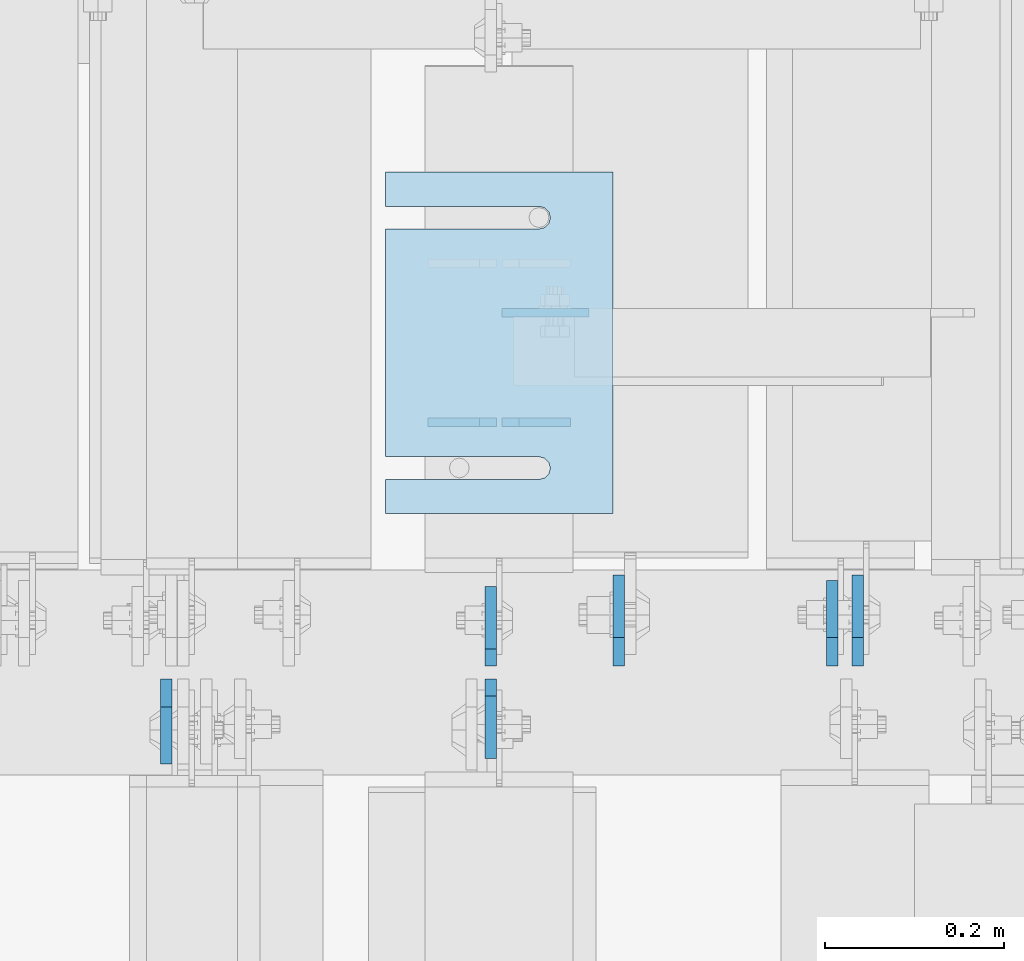
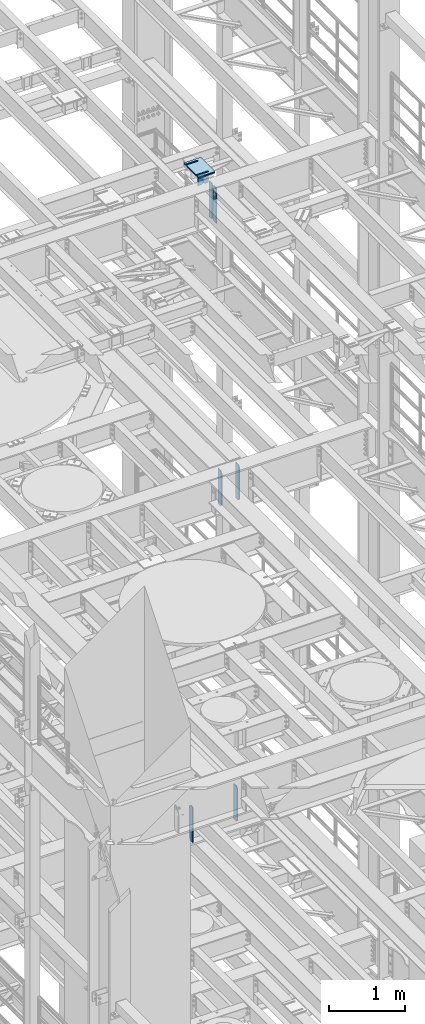
# One storey, part 1722 of 1876: 15 plates, 10 elements without a shape of their own.
"""IFC2X3 building model written with IfcOpenShell, lengths in millimetres."""

from ifc_helpers import new_model, si_unit, frame, origin_with_axes, place, context, subcontext, project, spatial, faceted_brep, material, type_object, element, aggregate, save


model = new_model("IFC2X3")

# Units and contexts
model_context = context("Model", 3, precision=1e-05, world=origin_with_axes())
body_context = subcontext(model_context, "Body", "Model", "MODEL_VIEW")
ifc_project = project(units=[si_unit("LENGTHUNIT", "METRE", prefix="MILLI"), si_unit("AREAUNIT", "SQUARE_METRE"), si_unit("VOLUMEUNIT", "CUBIC_METRE"), si_unit("MASSUNIT", "GRAM", prefix="KILO"), si_unit("TIMEUNIT", "SECOND"), si_unit("PLANEANGLEUNIT", "RADIAN"), si_unit("SOLIDANGLEUNIT", "STERADIAN"), si_unit("THERMODYNAMICTEMPERATUREUNIT", "DEGREE_CELSIUS"), si_unit("LUMINOUSINTENSITYUNIT", "LUMEN")], contexts=[model_context])

# Site, building, storey
site_placement = place(None, origin_with_axes())
site = spatial("IfcSite", under=ifc_project, at=site_placement, CompositionType="ELEMENT")
building_placement = place(site_placement, origin_with_axes())
building = spatial("IfcBuilding", under=site, at=building_placement, Name="Undefined", CompositionType="ELEMENT")
storey_placement = place(building_placement, origin_with_axes())
storey = spatial("IfcBuildingStorey", under=building, at=storey_placement, Name="Undefined", CompositionType="ELEMENT", Elevation=0.0)

# Assembly, plates
assembly_1_placement = place(storey_placement, origin_with_axes())
assembly_1 = element("IfcElementAssembly", 1, at=assembly_1_placement, inside=storey, Name="BEAM", AssemblyPlace="NOTDEFINED", PredefinedType="RIGID_FRAME")
ifc_material = material(Name="STEEL/A36")
plate_type_1 = type_object("IfcPlateType", PredefinedType="NOTDEFINED")
plate_1_placement = place(assembly_1_placement, frame((5184.77530602581, 7898.88123125041, 17792.7), z_axis=(0.0, 0.0, 1.0), x_axis=(-1.0, 0.0, 0.0)))
plate_1 = element("IfcPlate", 2, at=plate_1_placement, type_object=plate_type_1, material=ifc_material, Name="PLATE", context=body_context, shape_type="Brep", body=[
    faceted_brep([(0.0, -4.76249999999982, 0.0), (0.0, -4.76249999999982, 180.975006103516), (0.0, 4.76249999999982, 180.975006103516), (0.0, 4.76249999999982, 0.0), (57.1499977111816, -4.76249999999982, 180.975006103516), (57.1499977111816, 4.76249999999982, 180.975006103516), (76.1999969482422, -4.76249999999982, 161.925006866455), (76.1999969482422, 4.76249999999982, 161.925006866455), (76.1999969482422, -4.76249999999982, 19.0499992370605), (76.1999969482422, 4.76249999999982, 19.0499992370605), (57.1499977111816, -4.76249999999982, 0.0), (57.1499977111816, 4.76249999999982, 0.0)], [[[0, 1, 2, 3]], [[1, 4, 5, 2]], [[4, 6, 7, 5]], [[6, 8, 9, 7]], [[8, 10, 11, 9]], [[10, 0, 3, 11]], [[5, 7, 9, 11, 3, 2]], [[10, 8, 6, 4, 1, 0]]]),
])
plate_2_placement = place(assembly_1_placement, frame((5102.22530602581, 7898.88123125041, 17792.7), z_axis=(0.0, 0.0, 1.0), x_axis=(-1.0, 0.0, 0.0)))
plate_2 = element("IfcPlate", 3, at=plate_2_placement, type_object=plate_type_1, material=ifc_material, Name="PLATE", context=body_context, shape_type="Brep", body=[
    faceted_brep([(0.0, -4.76249999999982, 19.0499992370605), (0.0, -4.76249999999982, 161.925006866455), (0.0, 4.76249999999982, 161.925006866455), (0.0, 4.76249999999982, 19.0499992370605), (19.0499992370605, -4.76249999999982, 180.975006103516), (19.0499992370605, 4.76249999999982, 180.975006103516), (76.1999969482422, -4.76249999999982, 180.975006103516), (76.1999969482422, 4.76249999999982, 180.975006103516), (76.1999969482422, -4.76250000000073, 0.0), (76.1999969482422, 4.76250000000073, 0.0), (19.0499992370605, -4.76249999999982, 0.0), (19.0499992370605, 4.76249999999982, 0.0)], [[[0, 1, 2, 3]], [[1, 4, 5, 2]], [[4, 6, 7, 5]], [[6, 8, 9, 7]], [[8, 10, 11, 9]], [[10, 0, 3, 11]], [[5, 7, 9, 11, 3, 2]], [[10, 8, 6, 4, 1, 0]]]),
])
plate_type_2 = type_object("IfcPlateType", PredefinedType="NOTDEFINED")
plate_3_placement = place(assembly_1_placement, frame((5205.7390194183, 8021.0448743066, 17792.7), z_axis=(-1.0, 0.0, 0.0), x_axis=(0.0, 0.0, 1.0)))
plate_3 = element("IfcPlate", 4, at=plate_3_placement, type_object=plate_type_2, material=ifc_material, Name="PLATE", context=body_context, shape_type="Brep", body=[
    faceted_brep([(0.0, -4.76249999999982, 0.0), (-3.67032225767616e-05, -4.76249999998254, 84.4636888504128), (-3.67032225767616e-05, 4.7625000000171, 84.4636888504101), (0.0, 4.76249999999982, 0.0), (12.6999575873306, -4.76249999997981, 97.1636989145009), (12.6999575873306, 4.76250000001983, 97.163698914499), (85.0369567871567, -4.76249999998072, 97.1637573241951), (85.0369567871567, 4.76250000001983, 97.1637573241933), (85.0369949340893, -4.76250000000073, -1.68256519827992e-10), (85.0369949340893, 4.76249999999891, -1.70075509231538e-10)], [[[0, 1, 2, 3]], [[1, 4, 5, 2]], [[4, 6, 7, 5]], [[6, 8, 9, 7]], [[8, 0, 3, 9]], [[5, 7, 9, 3, 2]], [[8, 6, 4, 1, 0]]]),
])
aggregate(assembly_1, [plate_1, plate_2, plate_3])

assembly_2_placement = place(storey_placement, origin_with_axes())
assembly_2 = element("IfcElementAssembly", 5, at=assembly_2_placement, inside=storey, Name="BEAM", AssemblyPlace="NOTDEFINED", PredefinedType="RIGID_FRAME")
plate_type_3 = type_object("IfcPlateType", PredefinedType="NOTDEFINED")
plate_4_placement = place(assembly_2_placement, frame((5095.87401441426, 7612.85625, 17387.8875), z_axis=(0.0, 0.0, 1.0), x_axis=(0.0, -1.0, 0.0)))
plate_4 = element("IfcPlate", 6, at=plate_4_placement, type_object=plate_type_3, material=ifc_material, Name="PLATE", context=body_context, shape_type="Brep", body=[
    faceted_brep([(0.0, -6.35000000000196, 19.0499992370605), (0.0, -6.34999999999991, 550.862476348877), (0.0, 6.34999999999991, 550.862476348877), (0.0, 6.35000000000105, 19.0499992370605), (19.0499992370605, -6.34999999999991, 569.912475585938), (19.0499992370605, 6.34999999999991, 569.912475585938), (88.9000015258616, -6.35000000001173, 569.912475585938), (88.9000015258634, 6.34999999998627, 569.912475585938), (88.9000015258789, -6.34999999999991, 0.0), (88.9000015258789, 6.34999999999991, 0.0), (19.0499992370642, -6.35000000000105, 0.0), (19.0499992370633, 6.35000000000105, 0.0)], [[[0, 1, 2, 3]], [[1, 4, 5, 2]], [[4, 6, 7, 5]], [[6, 8, 9, 7]], [[8, 10, 11, 9]], [[10, 0, 3, 11]], [[5, 7, 9, 11, 3, 2]], [[10, 8, 6, 4, 1, 0]]]),
])
plate_5_placement = place(assembly_2_placement, frame((5095.87530593044, 7627.14375, 17387.8875), z_axis=(0.0, 0.0, 1.0), x_axis=(0.0, 1.0, 0.0)))
plate_5 = element("IfcPlate", 7, at=plate_5_placement, type_object=plate_type_3, material=ifc_material, Name="PLATE", context=body_context, shape_type="Brep", body=[
    faceted_brep([(0.0, -6.35000000000196, 19.0499992370605), (0.0, -6.34999999999991, 550.862476348877), (0.0, 6.34999999999991, 550.862476348877), (0.0, 6.35000000000105, 19.0499992370605), (19.0499992370605, -6.34999999999991, 569.912475585938), (19.0499992370605, 6.34999999999991, 569.912475585938), (88.9000015258616, -6.35000000001173, 569.912475585938), (88.9000015258634, 6.34999999998627, 569.912475585938), (88.9000015258789, -6.34999999999991, 0.0), (88.9000015258789, 6.34999999999991, 0.0), (19.0499992370642, -6.35000000000105, 0.0), (19.0499992370633, 6.35000000000105, 0.0)], [[[0, 1, 2, 3]], [[1, 4, 5, 2]], [[4, 6, 7, 5]], [[6, 8, 9, 7]], [[8, 10, 11, 9]], [[10, 0, 3, 11]], [[5, 7, 9, 11, 3, 2]], [[10, 8, 6, 4, 1, 0]]]),
])
aggregate(assembly_2, [plate_4, plate_5])

assembly_3_placement = place(storey_placement, origin_with_axes())
assembly_3 = element("IfcElementAssembly", 8, at=assembly_3_placement, inside=storey, Name="BEAM", AssemblyPlace="NOTDEFINED", PredefinedType="RIGID_FRAME")
plate_type_4 = type_object("IfcPlateType", PredefinedType="NOTDEFINED")
plate_6_placement = place(assembly_3_placement, frame((4733.92499990463, 7612.85625, 7558.0875), z_axis=(0.0, 0.0, 1.0), x_axis=(0.0, -1.0, 0.0)))
plate_6 = element("IfcPlate", 9, at=plate_6_placement, type_object=plate_type_4, material=ifc_material, Name="PLATE", context=body_context, shape_type="Brep", body=[
    faceted_brep([(0.0, -6.34999999999991, 31.75), (0.0, -6.35000000000036, 538.162475585938), (0.0, 6.35000000000036, 538.162475585938), (0.0, 6.34999999999991, 31.75), (31.75, -6.35000000000036, 569.912475585938), (31.75, 6.35000000000036, 569.912475585938), (95.25, -6.35000000000036, 569.912475585938), (95.25, 6.35000000000036, 569.912475585938), (95.25, -6.35000000000036, 0.0), (95.25, 6.35000000000036, 0.0), (31.75, -6.34999999999991, 0.0), (31.75, 6.34999999999991, 0.0)], [[[0, 1, 2, 3]], [[1, 4, 5, 2]], [[4, 6, 7, 5]], [[6, 8, 9, 7]], [[8, 10, 11, 9]], [[10, 0, 3, 11]], [[5, 7, 9, 11, 3, 2]], [[10, 8, 6, 4, 1, 0]]]),
])
plate_7_placement = place(assembly_3_placement, frame((5476.87499990463, 7627.14375, 7558.0875), z_axis=(0.0, 0.0, 1.0), x_axis=(0.0, 1.0, 0.0)))
plate_7 = element("IfcPlate", 10, at=plate_7_placement, type_object=plate_type_4, material=ifc_material, Name="PLATE", context=body_context, shape_type="Brep", body=[
    faceted_brep([(0.0, -6.34999999999991, 31.75), (0.0, -6.35000000000036, 538.162475585938), (0.0, 6.35000000000036, 538.162475585938), (0.0, 6.34999999999991, 31.75), (31.75, -6.35000000000036, 569.912475585938), (31.75, 6.35000000000036, 569.912475585938), (95.25, -6.35000000000036, 569.912475585938), (95.25, 6.35000000000036, 569.912475585938), (95.25, -6.35000000000036, 0.0), (95.25, 6.35000000000036, 0.0), (31.75, -6.34999999999991, 0.0), (31.75, 6.34999999999991, 0.0)], [[[0, 1, 2, 3]], [[1, 4, 5, 2]], [[4, 6, 7, 5]], [[6, 8, 9, 7]], [[8, 10, 11, 9]], [[10, 0, 3, 11]], [[5, 7, 9, 11, 3, 2]], [[10, 8, 6, 4, 1, 0]]]),
])
aggregate(assembly_3, [plate_6, plate_7])

assembly_4_placement = place(storey_placement, origin_with_axes())
assembly_4 = element("IfcElementAssembly", 11, at=assembly_4_placement, inside=storey, Name="BEAM", AssemblyPlace="NOTDEFINED", PredefinedType="RIGID_FRAME")
plate_type_5 = type_object("IfcPlateType", PredefinedType="NOTDEFINED")
plate_8_placement = place(assembly_4_placement, frame((5505.44999990463, 7627.14375, 12714.2875), z_axis=(0.0, 0.0, 1.0), x_axis=(0.0, 1.0, 0.0)))
plate_8 = element("IfcPlate", 12, at=plate_8_placement, type_object=plate_type_5, material=ifc_material, Name="PLATE", context=body_context, shape_type="Brep", body=[
    faceted_brep([(0.0, -6.34999999999991, 31.75), (0.0, -6.35000000000036, 538.162475585938), (0.0, 6.35000000000036, 538.162475585938), (0.0, 6.34999999999991, 31.75), (31.75, -6.35000000000036, 569.912475585938), (31.75, 6.35000000000036, 569.912475585938), (101.599998474121, -6.34999999999991, 569.912475585938), (101.599998474121, 6.34999999999991, 569.912475585938), (101.599998474121, -6.35000000000036, 0.0), (101.599998474121, 6.35000000000036, 0.0), (31.75, -6.34999999999991, 0.0), (31.75, 6.34999999999991, 0.0)], [[[0, 1, 2, 3]], [[1, 4, 5, 2]], [[4, 6, 7, 5]], [[6, 8, 9, 7]], [[8, 10, 11, 9]], [[10, 0, 3, 11]], [[5, 7, 9, 11, 3, 2]], [[10, 8, 6, 4, 1, 0]]]),
])
plate_9_placement = place(assembly_4_placement, frame((5238.74999834896, 7627.14375, 12714.2875), z_axis=(0.0, 0.0, 1.0), x_axis=(0.0, 1.0, 0.0)))
plate_9 = element("IfcPlate", 13, at=plate_9_placement, type_object=plate_type_5, material=ifc_material, Name="PLATE", context=body_context, shape_type="Brep", body=[
    faceted_brep([(0.0, -6.34999999999991, 31.75), (0.0, -6.35000000000036, 538.162475585938), (0.0, 6.35000000000036, 538.162475585938), (0.0, 6.34999999999991, 31.75), (31.75, -6.35000000000036, 569.912475585938), (31.75, 6.35000000000036, 569.912475585938), (101.599998474121, -6.34999999999991, 569.912475585938), (101.599998474121, 6.34999999999991, 569.912475585938), (101.599998474121, -6.35000000000036, 0.0), (101.599998474121, 6.35000000000036, 0.0), (31.75, -6.34999999999991, 0.0), (31.75, 6.34999999999991, 0.0)], [[[0, 1, 2, 3]], [[1, 4, 5, 2]], [[4, 6, 7, 5]], [[6, 8, 9, 7]], [[8, 10, 11, 9]], [[10, 0, 3, 11]], [[5, 7, 9, 11, 3, 2]], [[10, 8, 6, 4, 1, 0]]]),
])
aggregate(assembly_4, [plate_8, plate_9])

# Assembly, plate
assembly_5_placement = place(storey_placement, origin_with_axes())
assembly_5 = element("IfcElementAssembly", 14, at=assembly_5_placement, inside=storey, Name="SHIM PLATE", AssemblyPlace="NOTDEFINED", PredefinedType="RIGID_FRAME")
plate_type_6 = type_object("IfcPlateType", PredefinedType="NOTDEFINED")
plate_10_placement = place(assembly_5_placement, frame((5232.40173712284, 8178.20538047697, 18007.0115), z_axis=(-1.0, 0.0, 0.0), x_axis=(0.0, -1.0, 0.0)))
plate_10 = element("IfcPlate", 15, at=plate_10_placement, type_object=plate_type_6, material=ifc_material, Name="SHIM PLATE", context=body_context, shape_type="Brep", body=[
    faceted_brep([(38.1710562683074, -1.58750000000146, 253.999557495119), (38.1732778844053, -1.58750000000146, 82.6182316462764), (38.1732778844053, 1.58750000000146, 82.6182316462764), (38.1710562683074, 1.58750000000146, 253.999557495119), (39.8747477728821, -1.58750000000146, 76.2682283464169), (39.8747477728821, 1.58750000000146, 76.2682283464169), (44.523266268131, -1.58750000000146, 71.6196998169826), (44.523266268131, 1.58750000000146, 71.6196998169826), (50.8732658952267, -1.58750000000146, 69.9182162215529), (50.8732658952267, 1.58750000000146, 69.9182162215529), (57.2232684284982, -1.58750000000146, 71.6196889709886), (57.2232684284982, 1.58750000000146, 71.6196889709886), (61.8717948635667, -1.58750000000146, 76.2682095606051), (61.8717948635667, 1.58750000000146, 76.2682095606051), (63.5732755980398, -1.58750000000146, 82.6182099542939), (63.5732755980398, 1.58750000000146, 82.6182099542939), (63.5710539816291, -1.58750000000146, 253.999557596195), (63.5710539816291, 1.58750000000146, 253.99955749512), (9.09494701772928e-13, -1.58750000000146, 4.54747350886464e-13), (1.89071320164658e-05, -1.58750000000146, 253.999557495117), (1.89071320164658e-05, 1.58750000000146, 253.999557495117), (9.09494701772928e-13, 1.58750000000146, 4.54747350886464e-13), (380.998474121094, -1.58750000000146, -2.41016095969826e-11), (380.998474121094, 1.58750000000146, -2.41016095969826e-11), (380.998504638661, -1.58750000000146, 253.999557495133), (380.998504638661, 1.58750000000146, 253.999557495133), (342.971054337228, 1.58750000000146, 253.999557495132), (342.971054337228, -1.58750000000146, 253.999557596208), (342.973275782132, 1.58750000000146, 82.6182252130961), (342.973275782132, -1.58750000000146, 82.6182252130961), (341.271801399192, 1.58750000000146, 76.2682205744086), (341.271801399192, -1.58750000000146, 76.2682205744086), (336.623277411347, 1.58750000000146, 71.6196940636119), (336.623277411347, -1.58750000000146, 71.6196940636119), (330.273273696123, 1.58750000000146, 69.9182162342554), (330.273273696123, -1.58750000000146, 69.9182162342554), (323.923270846187, 1.58750000000146, 71.6196972929051), (323.923270846187, -1.58750000000146, 71.6196972929051), (319.274749222349, 1.58750000000146, 76.2682261677069), (319.274749222349, -1.58750000000146, 76.2682261677069), (317.573278068704, 1.58750000000146, 82.6182316716777), (317.573278068704, -1.58750000000146, 82.6182316716777), (317.571056623908, -1.58750000000146, 253.99955749513), (317.571056623908, 1.58750000000146, 253.99955749513)], [[[0, 1, 2, 3]], [[4, 5, 2, 1]], [[6, 7, 5, 4]], [[8, 9, 7, 6]], [[10, 11, 9, 8]], [[12, 13, 11, 10]], [[14, 15, 13, 12]], [[16, 17, 15, 14]], [[18, 19, 20, 21]], [[22, 18, 21, 23]], [[24, 22, 23, 25]], [[24, 25, 26, 27]], [[27, 26, 28, 29]], [[29, 28, 30, 31]], [[31, 30, 32, 33]], [[33, 32, 34, 35]], [[35, 34, 36, 37]], [[37, 36, 38, 39]], [[39, 38, 40, 41]], [[42, 41, 40, 43]], [[12, 10, 8, 6, 4, 1, 0, 19, 18, 22, 24, 27, 29, 31, 33, 35, 37, 39, 41, 42, 16, 14]], [[20, 19, 0, 3]], [[43, 40, 38, 36, 34, 32, 30, 28, 26, 25, 23, 21, 20, 3, 2, 5, 7, 9, 11, 13, 15, 17]], [[42, 43, 17, 16]]]),
])
aggregate(assembly_5, [plate_10])

assembly_6_placement = place(storey_placement, origin_with_axes())
assembly_6 = element("IfcElementAssembly", 16, at=assembly_6_placement, inside=storey, Name="SHIM PLATE", AssemblyPlace="NOTDEFINED", PredefinedType="RIGID_FRAME")
plate_11_placement = place(assembly_6_placement, frame((5232.40173712284, 8178.20538047697, 18003.8365), z_axis=(-1.0, 0.0, 0.0), x_axis=(0.0, -1.0, 0.0)))
plate_11 = element("IfcPlate", 17, at=plate_11_placement, type_object=plate_type_6, material=ifc_material, Name="SHIM PLATE", context=body_context, shape_type="Brep", body=[
    faceted_brep([(38.1710562683074, -1.58750000000146, 253.999557495119), (38.1732778844053, -1.58750000000146, 82.6182316462764), (38.1732778844053, 1.58750000000146, 82.6182316462764), (38.1710562683074, 1.58750000000146, 253.999557495119), (39.8747477728821, -1.58750000000146, 76.2682283464169), (39.8747477728821, 1.58750000000146, 76.2682283464169), (44.523266268131, -1.58750000000146, 71.6196998169826), (44.523266268131, 1.58750000000146, 71.6196998169826), (50.8732658952267, -1.58750000000146, 69.9182162215529), (50.8732658952267, 1.58750000000146, 69.9182162215529), (57.2232684284982, -1.58750000000146, 71.6196889709886), (57.2232684284982, 1.58750000000146, 71.6196889709886), (61.8717948635667, -1.58750000000146, 76.2682095606051), (61.8717948635667, 1.58750000000146, 76.2682095606051), (63.5732755980398, -1.58750000000146, 82.6182099542939), (63.5732755980398, 1.58750000000146, 82.6182099542939), (63.5710539816291, -1.58750000000146, 253.999557596195), (63.5710539816291, 1.58750000000146, 253.99955749512), (9.09494701772928e-13, -1.58750000000146, 4.54747350886464e-13), (1.89071320164658e-05, -1.58750000000146, 253.999557495117), (1.89071320164658e-05, 1.58750000000146, 253.999557495117), (9.09494701772928e-13, 1.58750000000146, 4.54747350886464e-13), (380.998474121094, -1.58750000000146, -2.41016095969826e-11), (380.998474121094, 1.58750000000146, -2.41016095969826e-11), (380.998504638661, -1.58750000000146, 253.999557495133), (380.998504638661, 1.58750000000146, 253.999557495133), (342.971054337228, 1.58750000000146, 253.999557495132), (342.971054337228, -1.58750000000146, 253.999557596208), (342.973275782132, 1.58750000000146, 82.6182252130961), (342.973275782132, -1.58750000000146, 82.6182252130961), (341.271801399192, 1.58750000000146, 76.2682205744086), (341.271801399192, -1.58750000000146, 76.2682205744086), (336.623277411347, 1.58750000000146, 71.6196940636119), (336.623277411347, -1.58750000000146, 71.6196940636119), (330.273273696123, 1.58750000000146, 69.9182162342554), (330.273273696123, -1.58750000000146, 69.9182162342554), (323.923270846187, 1.58750000000146, 71.6196972929051), (323.923270846187, -1.58750000000146, 71.6196972929051), (319.274749222349, 1.58750000000146, 76.2682261677069), (319.274749222349, -1.58750000000146, 76.2682261677069), (317.573278068704, 1.58750000000146, 82.6182316716777), (317.573278068704, -1.58750000000146, 82.6182316716777), (317.571056623908, -1.58750000000146, 253.99955749513), (317.571056623908, 1.58750000000146, 253.99955749513)], [[[0, 1, 2, 3]], [[4, 5, 2, 1]], [[6, 7, 5, 4]], [[8, 9, 7, 6]], [[10, 11, 9, 8]], [[12, 13, 11, 10]], [[14, 15, 13, 12]], [[16, 17, 15, 14]], [[18, 19, 20, 21]], [[22, 18, 21, 23]], [[24, 22, 23, 25]], [[24, 25, 26, 27]], [[27, 26, 28, 29]], [[29, 28, 30, 31]], [[31, 30, 32, 33]], [[33, 32, 34, 35]], [[35, 34, 36, 37]], [[37, 36, 38, 39]], [[39, 38, 40, 41]], [[42, 41, 40, 43]], [[12, 10, 8, 6, 4, 1, 0, 19, 18, 22, 24, 27, 29, 31, 33, 35, 37, 39, 41, 42, 16, 14]], [[20, 19, 0, 3]], [[43, 40, 38, 36, 34, 32, 30, 28, 26, 25, 23, 21, 20, 3, 2, 5, 7, 9, 11, 13, 15, 17]], [[42, 43, 17, 16]]]),
])
aggregate(assembly_6, [plate_11])

assembly_7_placement = place(storey_placement, origin_with_axes())
assembly_7 = element("IfcElementAssembly", 18, at=assembly_7_placement, inside=storey, Name="SHIM PLATE", AssemblyPlace="NOTDEFINED", PredefinedType="RIGID_FRAME")
plate_type_7 = type_object("IfcPlateType", PredefinedType="NOTDEFINED")
plate_12_placement = place(assembly_7_placement, frame((5232.40173712284, 8178.20538047697, 18009.3925), z_axis=(-1.0, 0.0, 0.0), x_axis=(0.0, -1.0, 0.0)))
plate_12 = element("IfcPlate", 19, at=plate_12_placement, type_object=plate_type_7, material=ifc_material, Name="SHIM PLATE", context=body_context, shape_type="Brep", body=[
    faceted_brep([(38.1710562683074, -0.793499999999767, 253.999557495119), (38.1732778844053, -0.793499999999767, 82.6182316462764), (38.1732778844053, 0.793499999999767, 82.6182316462764), (38.1710562683074, 0.793499999999767, 253.999557495119), (39.8747477728821, -0.793499999999767, 76.2682283464169), (39.8747477728821, 0.793499999999767, 76.2682283464169), (44.523266268131, -0.793499999999767, 71.6196998169826), (44.523266268131, 0.793499999999767, 71.6196998169826), (50.8732658952267, -0.793499999999767, 69.9182162215529), (50.8732658952267, 0.793499999999767, 69.9182162215529), (57.2232684284982, -0.793499999999767, 71.6196889709886), (57.2232684284982, 0.793499999999767, 71.6196889709886), (61.8717948635667, -0.793499999999767, 76.2682095606051), (61.8717948635667, 0.793499999999767, 76.2682095606051), (63.5732755980398, -0.793499999999767, 82.6182099542939), (63.5732755980398, 0.793499999999767, 82.6182099542939), (63.5710539816291, -0.793499999999767, 253.999557596195), (63.5710539816291, 0.793499999999767, 253.99955749512), (9.09494701772928e-13, -0.793499999999767, 0.0), (1.89070156011439e-05, -0.793499999999767, 253.999557495117), (1.89070156011439e-05, 0.793499999999767, 253.999557495117), (9.09494701772928e-13, 0.793499999999767, 0.0), (380.998474121094, -0.793499999999767, -2.41016095969826e-11), (380.998474121094, 0.793499999999767, -2.41016095969826e-11), (380.998504638661, -0.793499999999767, 253.999557495133), (380.998504638661, 0.793499999999767, 253.999557495133), (342.971054337228, 0.793499999999767, 253.999557495132), (342.971054337228, -0.793499999999767, 253.999557596208), (342.973275782132, 0.793499999999767, 82.6182252130961), (342.973275782132, -0.793499999999767, 82.6182252130961), (341.271801399192, 0.793499999999767, 76.2682205744086), (341.271801399192, -0.793499999999767, 76.2682205744086), (336.623277411347, 0.793499999999767, 71.6196940636119), (336.623277411347, -0.793499999999767, 71.6196940636119), (330.273273696123, 0.793499999999767, 69.9182162342554), (330.273273696123, -0.793499999999767, 69.9182162342554), (323.923270846187, 0.793499999999767, 71.6196972929051), (323.923270846187, -0.793499999999767, 71.6196972929051), (319.274749222349, 0.793499999999767, 76.2682261677069), (319.274749222349, -0.793499999999767, 76.2682261677069), (317.573278068704, 0.793499999999767, 82.6182316716777), (317.573278068704, -0.793499999999767, 82.6182316716777), (317.571056623908, -0.793499999999767, 253.99955749513), (317.571056623908, 0.793499999999767, 253.99955749513)], [[[0, 1, 2, 3]], [[4, 5, 2, 1]], [[6, 7, 5, 4]], [[8, 9, 7, 6]], [[10, 11, 9, 8]], [[12, 13, 11, 10]], [[14, 15, 13, 12]], [[16, 17, 15, 14]], [[18, 19, 20, 21]], [[22, 18, 21, 23]], [[24, 22, 23, 25]], [[24, 25, 26, 27]], [[27, 26, 28, 29]], [[29, 28, 30, 31]], [[31, 30, 32, 33]], [[33, 32, 34, 35]], [[35, 34, 36, 37]], [[37, 36, 38, 39]], [[39, 38, 40, 41]], [[42, 41, 40, 43]], [[12, 10, 8, 6, 4, 1, 0, 19, 18, 22, 24, 27, 29, 31, 33, 35, 37, 39, 41, 42, 16, 14]], [[20, 19, 0, 3]], [[43, 40, 38, 36, 34, 32, 30, 28, 26, 25, 23, 21, 20, 3, 2, 5, 7, 9, 11, 13, 15, 17]], [[42, 43, 17, 16]]]),
])
aggregate(assembly_7, [plate_12])

assembly_8_placement = place(storey_placement, origin_with_axes())
assembly_8 = element("IfcElementAssembly", 20, at=assembly_8_placement, inside=storey, Name="SHIM PLATE", AssemblyPlace="NOTDEFINED", PredefinedType="RIGID_FRAME")
plate_type_8 = type_object("IfcPlateType", PredefinedType="NOTDEFINED")
plate_13_placement = place(assembly_8_placement, frame((5232.40173712284, 8178.20538047697, 17999.868), z_axis=(-1.0, 0.0, 0.0), x_axis=(0.0, -1.0, 0.0)))
plate_13 = element("IfcPlate", 21, at=plate_13_placement, type_object=plate_type_8, material=ifc_material, Name="SHIM PLATE", context=body_context, shape_type="Brep", body=[
    faceted_brep([(38.1710562683056, -2.38100000000122, 253.999557495119), (38.1732778844034, -2.38100000000122, 82.6182316462764), (38.1732778844034, 2.38100000000122, 82.6182316462764), (38.1710562683056, 2.38100000000122, 253.999557495119), (39.8747477728803, -2.38100000000122, 76.2682283464169), (39.8747477728803, 2.38100000000122, 76.2682283464169), (44.5232662681292, -2.38100000000122, 71.6196998169826), (44.5232662681292, 2.38100000000122, 71.6196998169826), (50.8732658952249, -2.38100000000122, 69.9182162215529), (50.8732658952249, 2.38100000000122, 69.9182162215529), (57.2232684284963, -2.38100000000122, 71.6196889709886), (57.2232684284963, 2.38100000000122, 71.6196889709886), (61.8717948635649, -2.38100000000122, 76.2682095606051), (61.8717948635649, 2.38100000000122, 76.2682095606051), (63.573275598038, -2.38100000000122, 82.6182099542939), (63.573275598038, 2.38100000000122, 82.6182099542939), (63.5710539816273, -2.38100000000122, 253.999557596195), (63.5710539816273, 2.38100000000122, 253.99955749512), (0.0, -2.38100000000122, 4.54747350886464e-13), (1.89072484317876e-05, -2.38100000000122, 253.999557495117), (1.89072484317876e-05, 2.38100000000122, 253.999557495117), (0.0, 2.38100000000122, 4.54747350886464e-13), (380.998474121094, -2.38100000000122, -2.41016095969826e-11), (380.998474121094, 2.38100000000122, -2.41016095969826e-11), (380.998504638661, -2.38100000000122, 253.999557495133), (380.998504638661, 2.38100000000122, 253.999557495133), (342.971054337227, 2.38100000000122, 253.999557495132), (342.971054337227, -2.38100000000122, 253.999557596208), (342.97327578213, 2.38100000000122, 82.6182252130961), (342.97327578213, -2.38100000000122, 82.6182252130961), (341.27180139919, 2.38100000000122, 76.2682205744086), (341.27180139919, -2.38100000000122, 76.2682205744086), (336.623277411345, 2.38100000000122, 71.6196940636119), (336.623277411345, -2.38100000000122, 71.6196940636119), (330.273273696122, 2.38100000000122, 69.9182162342554), (330.273273696122, -2.38100000000122, 69.9182162342554), (323.923270846185, 2.38100000000122, 71.6196972929051), (323.923270846185, -2.38100000000122, 71.6196972929051), (319.274749222347, 2.38100000000122, 76.2682261677069), (319.274749222347, -2.38100000000122, 76.2682261677069), (317.573278068702, 2.38100000000122, 82.6182316716777), (317.573278068702, -2.38100000000122, 82.6182316716777), (317.571056623906, -2.38100000000122, 253.99955749513), (317.571056623906, 2.38100000000122, 253.99955749513)], [[[0, 1, 2, 3]], [[4, 5, 2, 1]], [[6, 7, 5, 4]], [[8, 9, 7, 6]], [[10, 11, 9, 8]], [[12, 13, 11, 10]], [[14, 15, 13, 12]], [[16, 17, 15, 14]], [[18, 19, 20, 21]], [[22, 18, 21, 23]], [[24, 22, 23, 25]], [[24, 25, 26, 27]], [[27, 26, 28, 29]], [[29, 28, 30, 31]], [[31, 30, 32, 33]], [[33, 32, 34, 35]], [[35, 34, 36, 37]], [[37, 36, 38, 39]], [[39, 38, 40, 41]], [[42, 41, 40, 43]], [[12, 10, 8, 6, 4, 1, 0, 19, 18, 22, 24, 27, 29, 31, 33, 35, 37, 39, 41, 42, 16, 14]], [[20, 19, 0, 3]], [[43, 40, 38, 36, 34, 32, 30, 28, 26, 25, 23, 21, 20, 3, 2, 5, 7, 9, 11, 13, 15, 17]], [[42, 43, 17, 16]]]),
])
aggregate(assembly_8, [plate_13])

assembly_9_placement = place(storey_placement, origin_with_axes())
assembly_9 = element("IfcElementAssembly", 22, at=assembly_9_placement, inside=storey, Name="SHIM PLATE", AssemblyPlace="NOTDEFINED", PredefinedType="RIGID_FRAME")
plate_14_placement = place(assembly_9_placement, frame((5232.40173712283, 8178.20538047697, 17995.106), z_axis=(-1.0, 0.0, 0.0), x_axis=(0.0, -1.0, 0.0)))
plate_14 = element("IfcPlate", 23, at=plate_14_placement, type_object=plate_type_8, material=ifc_material, Name="SHIM PLATE", context=body_context, shape_type="Brep", body=[
    faceted_brep([(38.1710562683056, -2.38100000000122, 253.999557495119), (38.1732778844034, -2.38100000000122, 82.6182316462764), (38.1732778844034, 2.38100000000122, 82.6182316462764), (38.1710562683056, 2.38100000000122, 253.999557495119), (39.8747477728803, -2.38100000000122, 76.2682283464169), (39.8747477728803, 2.38100000000122, 76.2682283464169), (44.5232662681292, -2.38100000000122, 71.6196998169826), (44.5232662681292, 2.38100000000122, 71.6196998169826), (50.8732658952249, -2.38100000000122, 69.9182162215529), (50.8732658952249, 2.38100000000122, 69.9182162215529), (57.2232684284963, -2.38100000000122, 71.6196889709886), (57.2232684284963, 2.38100000000122, 71.6196889709886), (61.8717948635649, -2.38100000000122, 76.2682095606051), (61.8717948635649, 2.38100000000122, 76.2682095606051), (63.573275598038, -2.38100000000122, 82.6182099542939), (63.573275598038, 2.38100000000122, 82.6182099542939), (63.5710539816273, -2.38100000000122, 253.999557596195), (63.5710539816273, 2.38100000000122, 253.99955749512), (0.0, -2.38100000000122, 4.54747350886464e-13), (1.89072484317876e-05, -2.38100000000122, 253.999557495117), (1.89072484317876e-05, 2.38100000000122, 253.999557495117), (0.0, 2.38100000000122, 4.54747350886464e-13), (380.998474121094, -2.38100000000122, -2.41016095969826e-11), (380.998474121094, 2.38100000000122, -2.41016095969826e-11), (380.998504638661, -2.38100000000122, 253.999557495133), (380.998504638661, 2.38100000000122, 253.999557495133), (342.971054337227, 2.38100000000122, 253.999557495132), (342.971054337227, -2.38100000000122, 253.999557596208), (342.97327578213, 2.38100000000122, 82.6182252130961), (342.97327578213, -2.38100000000122, 82.6182252130961), (341.27180139919, 2.38100000000122, 76.2682205744086), (341.27180139919, -2.38100000000122, 76.2682205744086), (336.623277411345, 2.38100000000122, 71.6196940636119), (336.623277411345, -2.38100000000122, 71.6196940636119), (330.273273696122, 2.38100000000122, 69.9182162342554), (330.273273696122, -2.38100000000122, 69.9182162342554), (323.923270846185, 2.38100000000122, 71.6196972929051), (323.923270846185, -2.38100000000122, 71.6196972929051), (319.274749222347, 2.38100000000122, 76.2682261677069), (319.274749222347, -2.38100000000122, 76.2682261677069), (317.573278068702, 2.38100000000122, 82.6182316716777), (317.573278068702, -2.38100000000122, 82.6182316716777), (317.571056623906, -2.38100000000122, 253.99955749513), (317.571056623906, 2.38100000000122, 253.99955749513)], [[[0, 1, 2, 3]], [[4, 5, 2, 1]], [[6, 7, 5, 4]], [[8, 9, 7, 6]], [[10, 11, 9, 8]], [[12, 13, 11, 10]], [[14, 15, 13, 12]], [[16, 17, 15, 14]], [[18, 19, 20, 21]], [[22, 18, 21, 23]], [[24, 22, 23, 25]], [[24, 25, 26, 27]], [[27, 26, 28, 29]], [[29, 28, 30, 31]], [[31, 30, 32, 33]], [[33, 32, 34, 35]], [[35, 34, 36, 37]], [[37, 36, 38, 39]], [[39, 38, 40, 41]], [[42, 41, 40, 43]], [[12, 10, 8, 6, 4, 1, 0, 19, 18, 22, 24, 27, 29, 31, 33, 35, 37, 39, 41, 42, 16, 14]], [[20, 19, 0, 3]], [[43, 40, 38, 36, 34, 32, 30, 28, 26, 25, 23, 21, 20, 3, 2, 5, 7, 9, 11, 13, 15, 17]], [[42, 43, 17, 16]]]),
])
aggregate(assembly_9, [plate_14])

assembly_10_placement = place(storey_placement, origin_with_axes())
assembly_10 = element("IfcElementAssembly", 24, at=assembly_10_placement, inside=storey, Name="SHIM PLATE", AssemblyPlace="NOTDEFINED", PredefinedType="RIGID_FRAME")
plate_type_9 = type_object("IfcPlateType", PredefinedType="NOTDEFINED")
plate_15_placement = place(assembly_10_placement, frame((5232.40173712283, 8178.20538047697, 17987.9625), z_axis=(-1.0, 0.0, 0.0), x_axis=(0.0, -1.0, 0.0)))
plate_15 = element("IfcPlate", 25, at=plate_15_placement, type_object=plate_type_9, material=ifc_material, Name="SHIM PLATE", context=body_context, shape_type="Brep", body=[
    faceted_brep([(38.1710562683074, -4.76250000000073, 253.999557495119), (38.1732778844053, -4.76250000000073, 82.6182316462764), (38.1732778844053, 4.76250000000073, 82.6182316462764), (38.1710562683074, 4.76250000000073, 253.999557495119), (39.8747477728821, -4.76250000000073, 76.2682283464169), (39.8747477728821, 4.76250000000073, 76.2682283464169), (44.523266268131, -4.76250000000073, 71.6196998169826), (44.523266268131, 4.76250000000073, 71.6196998169826), (50.8732658952267, -4.76250000000073, 69.9182162215529), (50.8732658952267, 4.76250000000073, 69.9182162215529), (57.2232684284982, -4.76250000000073, 71.6196889709886), (57.2232684284982, 4.76250000000073, 71.6196889709886), (61.8717948635667, -4.76250000000073, 76.2682095606051), (61.8717948635667, 4.76250000000073, 76.2682095606051), (63.5732755980398, -4.76250000000073, 82.6182099542939), (63.5732755980398, 4.76250000000073, 82.6182099542939), (63.5710539816291, -4.76250000000073, 253.999557596195), (63.5710539816291, 4.76250000000073, 253.99955749512), (0.0, -4.76249999999982, 0.0), (1.89073648471094e-05, -4.76250000000073, 253.999557495117), (1.89073648471094e-05, 4.76250000000073, 253.999557495117), (0.0, 4.76249999999982, 0.0), (380.998474121094, -4.76250000000073, -2.41016095969826e-11), (380.998474121094, 4.76250000000073, -2.41016095969826e-11), (380.998504638661, -4.76250000000073, 253.999557495133), (380.998504638661, 4.76250000000073, 253.999557495133), (342.971054337228, 4.76250000000073, 253.999557495132), (342.971054337228, -4.76250000000073, 253.999557596208), (342.973275782132, 4.76250000000073, 82.6182252130961), (342.973275782132, -4.76250000000073, 82.6182252130961), (341.271801399192, 4.76250000000073, 76.2682205744086), (341.271801399192, -4.76250000000073, 76.2682205744086), (336.623277411347, 4.76250000000073, 71.6196940636119), (336.623277411347, -4.76250000000073, 71.6196940636119), (330.273273696123, 4.76250000000073, 69.9182162342554), (330.273273696123, -4.76250000000073, 69.9182162342554), (323.923270846187, 4.76250000000073, 71.6196972929051), (323.923270846187, -4.76250000000073, 71.6196972929051), (319.274749222349, 4.76250000000073, 76.2682261677069), (319.274749222349, -4.76250000000073, 76.2682261677069), (317.573278068704, 4.76250000000073, 82.6182316716777), (317.573278068704, -4.76250000000073, 82.6182316716777), (317.571056623908, -4.76250000000073, 253.99955749513), (317.571056623908, 4.76250000000073, 253.99955749513)], [[[0, 1, 2, 3]], [[4, 5, 2, 1]], [[6, 7, 5, 4]], [[8, 9, 7, 6]], [[10, 11, 9, 8]], [[12, 13, 11, 10]], [[14, 15, 13, 12]], [[16, 17, 15, 14]], [[18, 19, 20, 21]], [[22, 18, 21, 23]], [[24, 22, 23, 25]], [[24, 25, 26, 27]], [[27, 26, 28, 29]], [[29, 28, 30, 31]], [[31, 30, 32, 33]], [[33, 32, 34, 35]], [[35, 34, 36, 37]], [[37, 36, 38, 39]], [[39, 38, 40, 41]], [[42, 41, 40, 43]], [[12, 10, 8, 6, 4, 1, 0, 19, 18, 22, 24, 27, 29, 31, 33, 35, 37, 39, 41, 42, 16, 14]], [[20, 19, 0, 3]], [[43, 40, 38, 36, 34, 32, 30, 28, 26, 25, 23, 21, 20, 3, 2, 5, 7, 9, 11, 13, 15, 17]], [[42, 43, 17, 16]]]),
])
aggregate(assembly_10, [plate_15])

save(model, "model.ifc")
